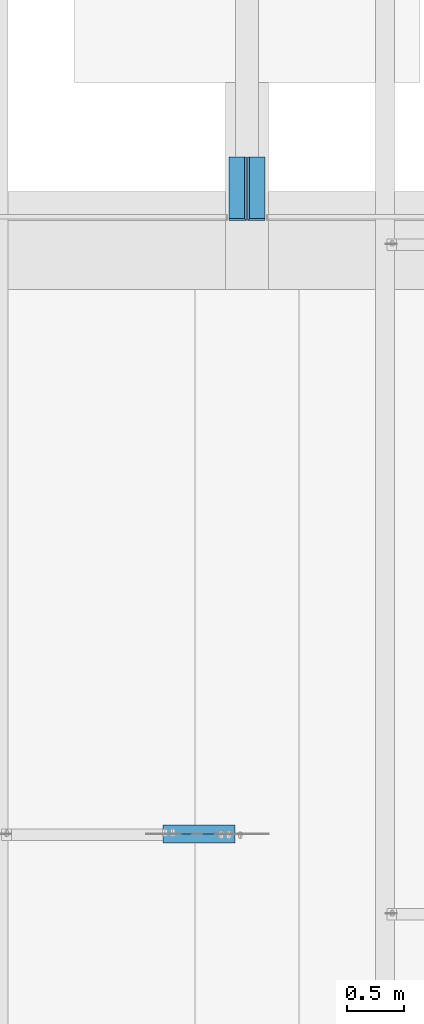
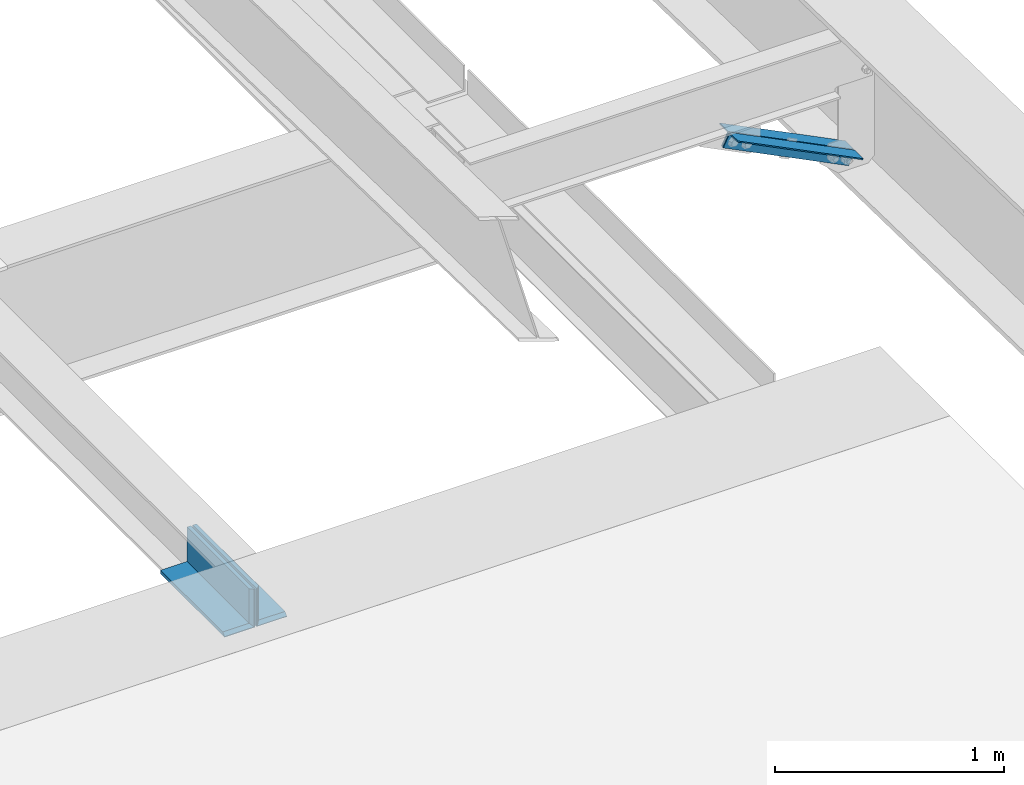
# One storey, part 1326 of 1763: 2 beams, 2 members, 3 elements without a shape of their own.
"""IFC2X3 building model written with IfcOpenShell, lengths in millimetres."""

from ifc_helpers import new_model, si_unit, frame, origin_with_axes, place, context, subcontext, project, spatial, faceted_brep, material, type_object, element, aggregate, save


model = new_model("IFC2X3")

# Units and contexts
model_context = context("Model", 3, precision=1e-05, world=origin_with_axes())
body_context = subcontext(model_context, "Body", "Model", "MODEL_VIEW")
ifc_project = project(units=[si_unit("LENGTHUNIT", "METRE", prefix="MILLI"), si_unit("AREAUNIT", "SQUARE_METRE"), si_unit("VOLUMEUNIT", "CUBIC_METRE"), si_unit("MASSUNIT", "GRAM", prefix="KILO"), si_unit("TIMEUNIT", "SECOND"), si_unit("PLANEANGLEUNIT", "RADIAN"), si_unit("SOLIDANGLEUNIT", "STERADIAN"), si_unit("THERMODYNAMICTEMPERATUREUNIT", "DEGREE_CELSIUS"), si_unit("LUMINOUSINTENSITYUNIT", "LUMEN")], contexts=[model_context])

# Site, building, storey
site_placement = place(None, origin_with_axes())
site = spatial("IfcSite", under=ifc_project, at=site_placement, CompositionType="ELEMENT")
building_placement = place(site_placement, origin_with_axes())
building = spatial("IfcBuilding", under=site, at=building_placement, Name="Undefined", CompositionType="ELEMENT")
storey_placement = place(building_placement, origin_with_axes())
storey = spatial("IfcBuildingStorey", under=building, at=storey_placement, Name="Undefined", CompositionType="ELEMENT", Elevation=0.0)

# Assembly, members
assembly_1_placement = place(storey_placement, origin_with_axes())
assembly_1 = element("IfcElementAssembly", 1, at=assembly_1_placement, inside=storey, Name="BEAM", AssemblyPlace="NOTDEFINED", PredefinedType="RIGID_FRAME")
ifc_material = material(Name="STEEL/A36")
member_type = type_object("IfcMemberType", Name="L3X3X1/4", PredefinedType="NOTDEFINED")
member_1_placement = place(assembly_1_placement, frame((-24152.7887495855, 21821.7750000279, 10773.8271962947), z_axis=(-0.447213595099945, 0.0, -0.894427191199922), x_axis=(-0.894427191199916, 0.0, 0.447213595099958)))
member_1 = element("IfcMember", 2, at=member_1_placement, type_object=member_type, material=ifc_material, Name="BEAM", ObjectType="L3X3X1/4", context=body_context, shape_type="Brep", body=[
    faceted_brep([(0.0, 38.0999999999985, -38.1000000000004), (0.0, 38.0999999999985, 38.1000000000004), (707.506960093262, 38.0999999999985, 38.100000000162), (707.506960093277, 38.0999999999985, -38.0999999998805), (0.0, 31.75, 38.1000000000058), (707.506960093262, 31.75, 38.100000000162), (0.0, 31.75, -31.75), (707.506960093277, 31.75, -31.7499999998784), (0.0, -38.1000000000004, -31.75), (707.506960093277, -38.0999999999985, -31.7499999998784), (0.0, -38.0999999999985, -38.1000000000004), (707.506960093277, -38.0999999999985, -38.0999999998805)], [[[0, 1, 2, 3]], [[1, 4, 5, 2]], [[4, 6, 7, 5]], [[6, 8, 9, 7]], [[8, 10, 11, 9]], [[10, 0, 3, 11]], [[5, 7, 9, 11, 3, 2]], [[10, 8, 6, 4, 1, 0]]]),
])
member_2_placement = place(assembly_1_placement, frame((-24785.6022126537, 21904.3250000301, 11090.2339274792), z_axis=(-0.447213595099945, 0.0, -0.894427191199922), x_axis=(0.894427191199916, 0.0, -0.447213595099958)))
member_2 = element("IfcMember", 3, at=member_2_placement, type_object=member_type, material=ifc_material, Name="BEAM", ObjectType="L3X3X1/4", context=body_context, shape_type="Brep", body=[
    faceted_brep([(0.0, 38.0999999999985, -38.1000000000004), (0.0, 38.0999999999985, 38.1000000000004), (707.506960093262, 38.0999999999985, 38.100000000162), (707.506960093277, 38.0999999999985, -38.0999999998805), (0.0, 31.75, 38.1000000000058), (707.506960093262, 31.75, 38.100000000162), (0.0, 31.75, -31.75), (707.506960093277, 31.75, -31.7499999998784), (0.0, -38.1000000000004, -31.75), (707.506960093277, -38.0999999999985, -31.7499999998784), (0.0, -38.0999999999985, -38.1000000000004), (707.506960093277, -38.0999999999985, -38.0999999998805)], [[[0, 1, 2, 3]], [[1, 4, 5, 2]], [[4, 6, 7, 5]], [[6, 8, 9, 7]], [[8, 10, 11, 9]], [[10, 0, 3, 11]], [[5, 7, 9, 11, 3, 2]], [[10, 8, 6, 4, 1, 0]]]),
])
aggregate(assembly_1, [member_1, member_2])

# Assembly, beam
assembly_2_placement = place(storey_placement, origin_with_axes())
assembly_2 = element("IfcElementAssembly", 4, at=assembly_2_placement, inside=storey, Name="ANGLE", AssemblyPlace="NOTDEFINED", PredefinedType="RIGID_FRAME")
beam_type = type_object("IfcBeamType", Name="L8X6X3/4", PredefinedType="NOTDEFINED")
beam_1_placement = place(assembly_2_placement, frame((-23946.8747736984, 27279.6, 5041.9), z_axis=(0.0, 0.0, 1.0), x_axis=(0.0, 1.0, 0.0)))
beam_1 = element("IfcBeam", 5, at=beam_1_placement, type_object=beam_type, material=ifc_material, Name="ANGLE", ObjectType="L8X6X3/4", context=body_context, shape_type="Brep", body=[
    faceted_brep([(0.0, 73.0249999999942, -98.4250000000002), (15.875, 57.1499999999942, -82.5500000000002), (15.875, 57.1499999999942, 101.6), (0.0, 73.0249999999942, 101.6), (0.0, -76.1999999999971, -98.4250000000002), (15.875, -76.1999999999971, -82.5500000000002), (558.799999999999, 57.1499999999942, -82.5500000000002), (558.799999999999, 57.1499999999942, 101.6), (0.0, 76.1999999999971, -101.6), (0.0, 76.1999999999971, 101.6), (558.799999999999, 76.1999999999971, 101.6), (558.799999999999, 76.1999999999971, -101.6), (558.799999999999, -76.1999999999971, -82.5500000000002), (0.0, -76.1999999999971, -101.6), (558.799999999999, -76.1999999999971, -101.6)], [[[0, 1, 2, 3]], [[4, 5, 1, 0]], [[6, 7, 2, 1]], [[8, 9, 10, 11]], [[7, 10, 9, 3, 2]], [[12, 6, 1, 5]], [[13, 14, 12, 5, 4]], [[13, 8, 11, 14]], [[7, 6, 12, 14, 11, 10]], [[9, 8, 13, 4, 0, 3]]]),
])
aggregate(assembly_2, [beam_1])

assembly_3_placement = place(storey_placement, origin_with_axes())
assembly_3 = element("IfcElementAssembly", 6, at=assembly_3_placement, inside=storey, Name="ANGLE", AssemblyPlace="NOTDEFINED", PredefinedType="RIGID_FRAME")
beam_2_placement = place(assembly_3_placement, frame((-24108.7997736984, 27838.4, 5041.9), z_axis=(0.0, 0.0, 1.0), x_axis=(0.0, -1.0, 0.0)))
beam_2 = element("IfcBeam", 7, at=beam_2_placement, type_object=beam_type, material=ifc_material, Name="ANGLE", ObjectType="L8X6X3/4", context=body_context, shape_type="Brep", body=[
    faceted_brep([(558.799999999999, 73.0249999999942, -98.4250000000002), (542.924999999999, 57.1499999999942, -82.5500000000002), (542.924999999999, -76.1999999999971, -82.5500000000002), (558.799999999999, -76.1999999999971, -98.4250000000002), (558.799999999999, 73.0249999999942, 101.6), (542.924999999999, 57.1499999999942, 101.6), (0.0, 57.1499999999942, -82.5500000000002), (0.0, -76.1999999999971, -82.5500000000002), (0.0, 76.1999999999971, -101.6), (0.0, 76.1999999999971, 101.6), (558.799999999999, 76.1999999999971, 101.6), (558.799999999999, 76.1999999999971, -101.6), (0.0, 57.1499999999942, 101.6), (0.0, -76.1999999999971, -101.6), (558.799999999999, -76.1999999999971, -101.6)], [[[0, 1, 2, 3]], [[4, 5, 1, 0]], [[6, 7, 2, 1]], [[8, 9, 10, 11]], [[10, 9, 12, 5, 4]], [[12, 6, 1, 5]], [[7, 13, 14, 3, 2]], [[13, 8, 11, 14]], [[14, 11, 10, 4, 0, 3]], [[13, 7, 6, 12, 9, 8]]]),
])
aggregate(assembly_3, [beam_2])

save(model, "model.ifc")
